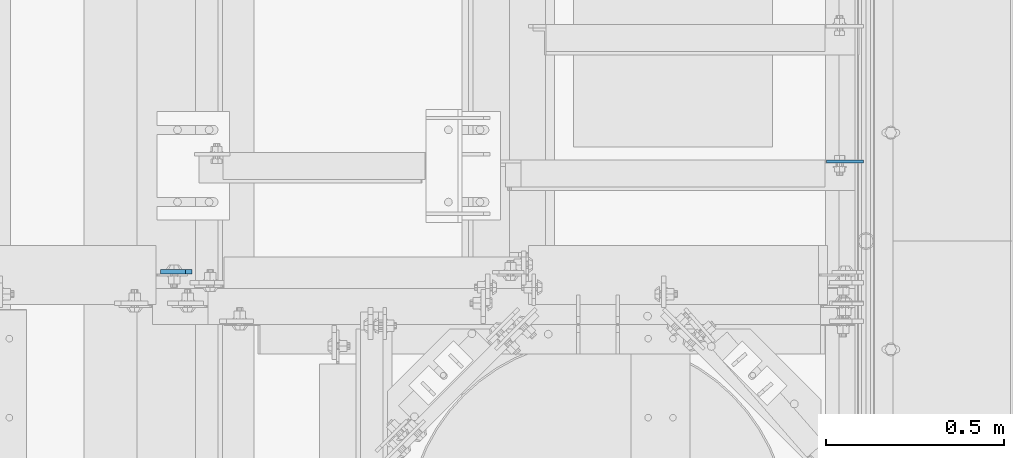
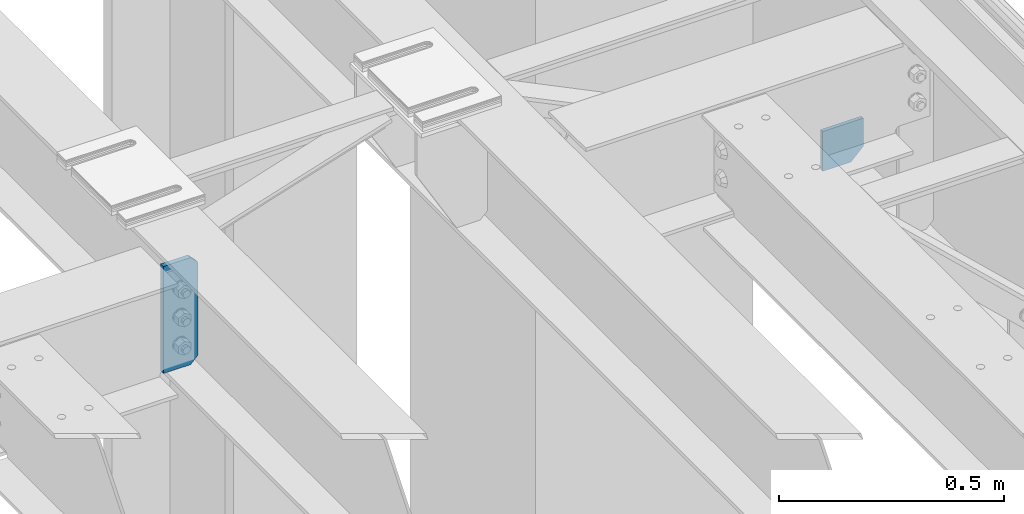
# One storey, part 1661 of 1876: 2 plates, 2 elements without a shape of their own.
"""IFC2X3 building model written with IfcOpenShell, lengths in millimetres."""

from ifc_helpers import new_model, si_unit, frame, origin_with_axes, place, context, subcontext, project, spatial, faceted_brep, material, type_object, element, aggregate, save


model = new_model("IFC2X3")

# Units and contexts
model_context = context("Model", 3, precision=1e-05, world=origin_with_axes())
body_context = subcontext(model_context, "Body", "Model", "MODEL_VIEW")
ifc_project = project(units=[si_unit("LENGTHUNIT", "METRE", prefix="MILLI"), si_unit("AREAUNIT", "SQUARE_METRE"), si_unit("VOLUMEUNIT", "CUBIC_METRE"), si_unit("MASSUNIT", "GRAM", prefix="KILO"), si_unit("TIMEUNIT", "SECOND"), si_unit("PLANEANGLEUNIT", "RADIAN"), si_unit("SOLIDANGLEUNIT", "STERADIAN"), si_unit("THERMODYNAMICTEMPERATUREUNIT", "DEGREE_CELSIUS"), si_unit("LUMINOUSINTENSITYUNIT", "LUMEN")], contexts=[model_context])

# Site, building, storey
site_placement = place(None, origin_with_axes())
site = spatial("IfcSite", under=ifc_project, at=site_placement, CompositionType="ELEMENT")
building_placement = place(site_placement, origin_with_axes())
building = spatial("IfcBuilding", under=site, at=building_placement, Name="Undefined", CompositionType="ELEMENT")
storey_placement = place(building_placement, origin_with_axes())
storey = spatial("IfcBuildingStorey", under=building, at=storey_placement, Name="Undefined", CompositionType="ELEMENT", Elevation=0.0)

# Assembly, plate
assembly_1_placement = place(storey_placement, origin_with_axes())
assembly_1 = element("IfcElementAssembly", 1, at=assembly_1_placement, inside=storey, Name="BEAM", AssemblyPlace="NOTDEFINED", PredefinedType="RIGID_FRAME")
ifc_material = material(Name="STEEL/A36")
plate_type_1 = type_object("IfcPlateType", PredefinedType="NOTDEFINED")
plate_1_placement = place(assembly_1_placement, frame((7508.34074252197, 4795.8375, 4641.9553873822), z_axis=(1.0, 0.0, 0.0), x_axis=(0.0, 0.0, -1.0)))
plate_1 = element("IfcPlate", 2, at=plate_1_placement, type_object=plate_type_1, material=ifc_material, Name="PLATE", context=body_context, shape_type="Brep", body=[
    faceted_brep([(0.0, -4.76249999999982, 0.0), (0.0, -4.76249999999982, 104.515510559082), (0.0, 4.76249999999982, 104.515510559082), (0.0, 4.76249999999982, 0.0), (76.3053894042969, -4.76249999999982, 104.515510559082), (76.3053894042969, 4.76249999999982, 104.515510559082), (108.055389404297, -4.76249999999982, 72.765510559082), (108.055389404297, 4.76249999999982, 72.765510559082), (108.055389404297, -4.76249999999982, 0.0), (108.055389404297, 4.76249999999982, 0.0)], [[[0, 1, 2, 3]], [[1, 4, 5, 2]], [[4, 6, 7, 5]], [[6, 8, 9, 7]], [[8, 0, 3, 9]], [[5, 7, 9, 3, 2]], [[8, 6, 4, 1, 0]]]),
])
aggregate(assembly_1, [plate_1])

assembly_2_placement = place(storey_placement, origin_with_axes())
assembly_2 = element("IfcElementAssembly", 3, at=assembly_2_placement, inside=storey, Name="BEAM", AssemblyPlace="NOTDEFINED", PredefinedType="RIGID_FRAME")
plate_type_2 = type_object("IfcPlateType", PredefinedType="NOTDEFINED")
plate_2_placement = place(assembly_2_placement, frame((5724.525, 4486.27500009537, 4829.175), z_axis=(0.0, 0.0, 1.0), x_axis=(-1.0, 0.0, 0.0)))
plate_2 = element("IfcPlate", 4, at=plate_2_placement, type_object=plate_type_2, material=ifc_material, Name="PLATE", context=body_context, shape_type="Brep", body=[
    faceted_brep([(0.0, -6.35000000000196, 19.0499992370605), (0.0, -6.35000000000036, 271.462512969971), (0.0, 6.35000000000036, 271.462512969971), (0.0, 6.35000000000105, 19.0499992370605), (19.0499992370605, -6.35000000000036, 290.512512207031), (19.0499992370605, 6.35000000000036, 290.512512207031), (88.9000015258789, -6.35000000000036, 290.512512207031), (88.9000015258789, 6.35000000000036, 290.512512207031), (88.9000015258789, -6.34999999999991, 0.0), (88.9000015258789, 6.34999999999991, 0.0), (19.0499992370642, -6.35000000000105, 0.0), (19.0499992370633, 6.35000000000105, 0.0)], [[[0, 1, 2, 3]], [[1, 4, 5, 2]], [[4, 6, 7, 5]], [[6, 8, 9, 7]], [[8, 10, 11, 9]], [[10, 0, 3, 11]], [[5, 7, 9, 11, 3, 2]], [[10, 8, 6, 4, 1, 0]]]),
])
aggregate(assembly_2, [plate_2])

save(model, "model.ifc")
